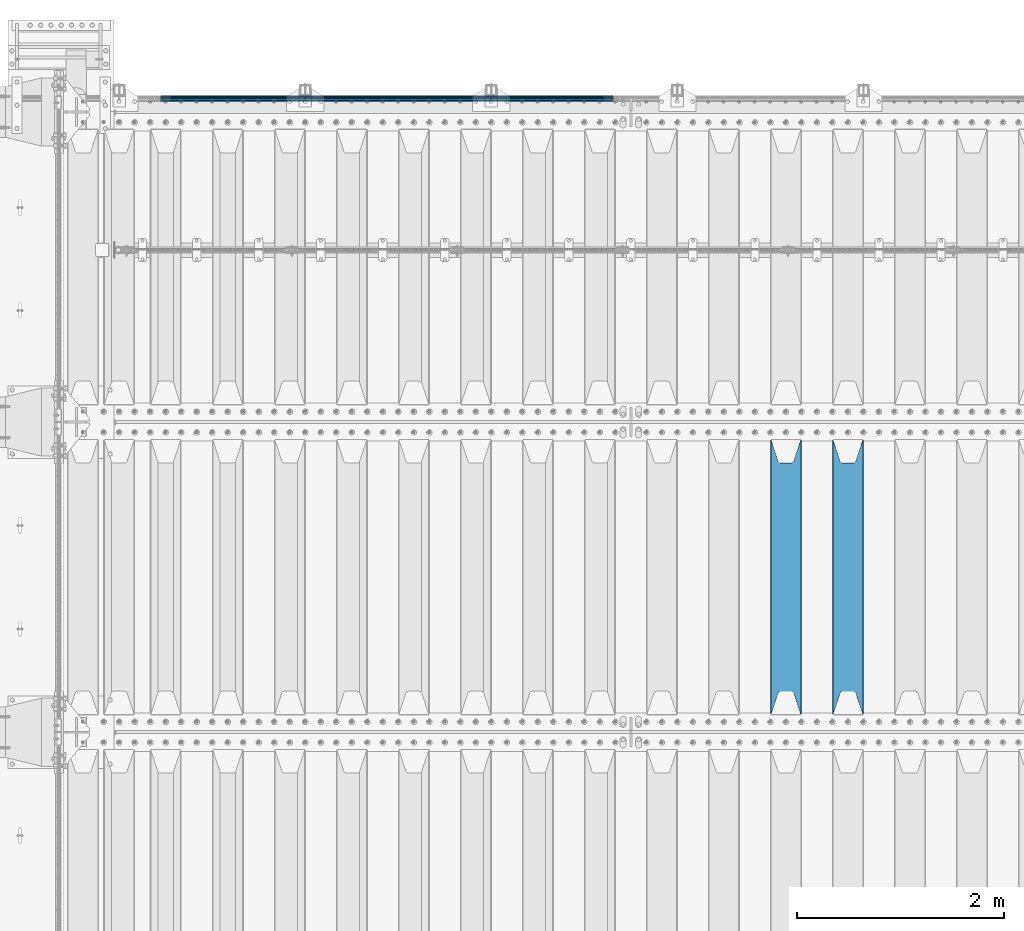
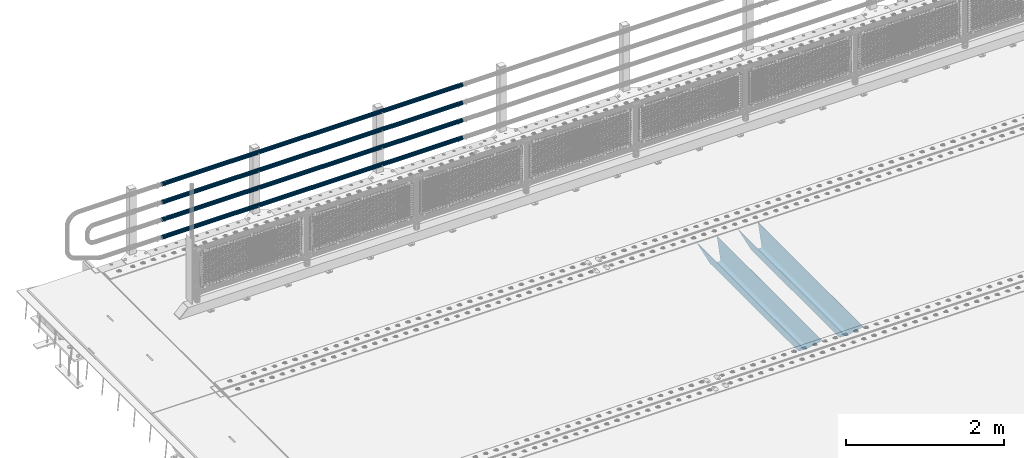
# One storey, part 120 of 257: 6 beams.
"""IFC2X3 building model written with IfcOpenShell, lengths in millimetres."""

import ifcopenshell
import ifcopenshell.guid

model = None  # the IFC model being written
_history = None  # IfcOwnerHistory: only IFC2X3 demands one
_inside = {}  # id of a spatial element -> (the spatial element, [elements in it])
_under = {}  # id of a project, library or spatial element -> (it, [spatial elements below it])
_declared = {}  # id of a project -> (the project, [libraries it declares])
_typed = {}  # id of a type object -> (the type object, [elements of that type])
_made_of = {}  # id of a material, layer set ... -> (it, [elements and type objects made of it])


def new_model(schema):
    """Start an empty IFC model of exactly this schema.

    Asked for "IFC4X3", IfcOpenShell would pick the latest addendum, in which some entities
    have other attributes; the version numbers below select the first issue.
    IFC2X3 requires an IfcOwnerHistory on every rooted entity: one is made here for all.
    """
    global model, _history
    if schema == "IFC4X3":
        model = ifcopenshell.file(schema_version=(4, 3, 0, 0))
    else:
        model = ifcopenshell.file(schema=schema)
    _inside.clear()
    _under.clear()
    _declared.clear()
    _typed.clear()
    _made_of.clear()
    _history = None
    if model.schema == "IFC2X3":
        org = make("IfcOrganization", Name="unknown")
        user = make(
            "IfcPersonAndOrganization",
            ThePerson=make("IfcPerson", FamilyName="unknown"),
            TheOrganization=org,
        )
        app = make(
            "IfcApplication",
            ApplicationDeveloper=org,
            Version="unknown",
            ApplicationFullName="unknown",
            ApplicationIdentifier="unknown",
        )
        _history = make(
            "IfcOwnerHistory",
            OwningUser=user,
            OwningApplication=app,
            ChangeAction="ADDED",
            CreationDate=0,
        )
    return model


def make(cls, **values):
    """One entity of the class cls with the attributes given. An attribute that is None is left unset."""
    return model.create_entity(
        cls, **{name: value for name, value in values.items() if value is not None}
    )


def rooted(cls, **values):
    """An entity with a GlobalId (a new one), such as an element, a storey or a relation."""
    return make(cls, GlobalId=ifcopenshell.guid.new(), OwnerHistory=_history, **values)


def si_unit(unit_type, name, prefix=None):
    """IfcSIUnit, for example si_unit("LENGTHUNIT", "METRE", prefix="MILLI")."""
    return make("IfcSIUnit", UnitType=unit_type, Prefix=prefix, Name=name)


def assignment(units):
    """IfcUnitAssignment: the units of a project."""
    return None if units is None else make("IfcUnitAssignment", Units=units)


def point(xyz):
    """IfcCartesianPoint."""
    return None if xyz is None else make("IfcCartesianPoint", Coordinates=xyz)


def direction(xyz):
    """IfcDirection."""
    return None if xyz is None else make("IfcDirection", DirectionRatios=xyz)


def frame(location, z_axis=None, x_axis=None):
    """IfcAxis2Placement3D, a coordinate frame: its origin and axes. An axis left out is left unset."""
    return make(
        "IfcAxis2Placement3D",
        Location=point(location),
        Axis=direction(z_axis),
        RefDirection=direction(x_axis),
    )


def origin_with_axes():
    """The frame at (0, 0, 0) with the z axis (0, 0, 1) and the x axis (1, 0, 0) written out."""
    return frame((0.0, 0.0, 0.0), z_axis=(0.0, 0.0, 1.0), x_axis=(1.0, 0.0, 0.0))


def place(relative_to, where):
    """IfcLocalPlacement: puts the frame where relative to a parent placement (None: the world)."""
    return make(
        "IfcLocalPlacement", PlacementRelTo=relative_to, RelativePlacement=where
    )


def context(
    kind, dimensions, precision=None, world=None, true_north=None, identifier=None
):
    """IfcGeometricRepresentationContext, for example the 3D "Model" context."""
    return make(
        "IfcGeometricRepresentationContext",
        ContextIdentifier=identifier,
        ContextType=kind,
        CoordinateSpaceDimension=dimensions,
        Precision=precision,
        WorldCoordinateSystem=world,
        TrueNorth=true_north,
    )


def subcontext(parent, identifier, kind, view, scale=None):
    """IfcGeometricRepresentationSubContext, for example "Body" below "Model"."""
    return make(
        "IfcGeometricRepresentationSubContext",
        ContextIdentifier=identifier,
        ContextType=kind,
        ParentContext=parent,
        TargetScale=scale,
        TargetView=view,
    )


def project(units=None, contexts=None):
    """IfcProject with its units and contexts."""
    return rooted(
        "IfcProject",
        Name="project",
        RepresentationContexts=contexts,
        UnitsInContext=assignment(units),
    )


def spatial(cls, under=None, at=None, **own):
    """A site, building, storey or space (cls), placed at a placement, below another one or the project."""
    s = rooted(cls, ObjectPlacement=at, **own)
    if under is not None:
        _under.setdefault(under.id(), (under, []))[1].append(s)
    return s


def faces_of(points, faces, orient=None, outer=None):
    """IfcFace entities. A face is a list of loops; a loop is a list of indices into points, from 0.

    orient and outer hold one flag for each loop. By default every Orientation is true, the
    first loop of a face is its IfcFaceOuterBound and the others are IfcFaceBound.
    """
    made = []
    for i, loops in enumerate(faces):
        bounds = []
        for j, loop in enumerate(loops):
            is_outer = j == 0 if outer is None else outer[i][j]
            bounds.append(
                make(
                    "IfcFaceOuterBound" if is_outer else "IfcFaceBound",
                    Bound=make("IfcPolyLoop", Polygon=[points[k] for k in loop]),
                    Orientation=True if orient is None else orient[i][j],
                )
            )
        made.append(make("IfcFace", Bounds=bounds))
    return made


def faceted_brep(points, faces, orient=None, outer=None, voids=None):
    """IfcFacetedBrep: a solid bounded by flat faces; with voids (closed shells), ...WithVoids."""
    shared = [point(p) for p in points]
    hull = make("IfcClosedShell", CfsFaces=faces_of(shared, faces, orient, outer))
    if voids is None:
        return make("IfcFacetedBrep", Outer=hull)
    return make(
        "IfcFacetedBrepWithVoids",
        Outer=hull,
        Voids=[
            make(cls, CfsFaces=faces_of(shared, fs, o, b)) for cls, fs, o, b in voids
        ],
    )


def shape(context_of_items, identifier, shape_type, items):
    """IfcShapeRepresentation: the items that make up one representation, for example the "Body"."""
    return make(
        "IfcShapeRepresentation",
        ContextOfItems=context_of_items,
        RepresentationIdentifier=identifier,
        RepresentationType=shape_type,
        Items=items,
    )


def material(Name=None, Category=None):
    """IfcMaterial."""
    return make("IfcMaterial", Name=Name, Category=Category)


def made_of(thing, what):
    """Note that an element or type object is made of a material, layer set ...; save() writes the relation."""
    if what is not None:
        _made_of.setdefault(what.id(), (what, []))[1].append(thing)
    return thing


def type_object(cls, material=None, **own):
    """A type object (cls), such as IfcWallType, which elements share."""
    return made_of(rooted(cls, **own), material)


def element(
    cls,
    number,
    at=None,
    inside=None,
    cuts=None,
    type_object=None,
    material=None,
    context=None,
    identifier="Body",
    shape_type=None,
    held_by="IfcProductDefinitionShape",
    body=None,
    shapes=None,
    **own,
):
    """One element of the class cls, such as IfcWall. Its Tag is "e" and its number.

    at: its placement. inside: the storey or other place that contains it. cuts: it is an
    opening in that element (IfcRelVoidsElement). A single representation is given by context,
    identifier, shape_type and body (its items); several are given by shapes. held_by: the class
    of the entity that holds the representations. save() writes the other relations.
    """
    e = rooted(cls, Tag="e%d" % number, ObjectPlacement=at, **own)
    if body is not None:
        shapes = [shape(context, identifier, shape_type, body)]
    if shapes is not None:
        e.Representation = make(held_by, Representations=shapes)
    if inside is not None:
        _inside.setdefault(inside.id(), (inside, []))[1].append(e)
    if cuts is not None:
        rooted(
            "IfcRelVoidsElement", RelatingBuildingElement=cuts, RelatedOpeningElement=e
        )
    if type_object is not None:
        _typed.setdefault(type_object.id(), (type_object, []))[1].append(e)
    return made_of(e, material)


def aggregate(whole, parts):
    """IfcRelAggregates: a whole, such as a stair, and the parts it consists of."""
    return rooted("IfcRelAggregates", RelatingObject=whole, RelatedObjects=parts)


def save(model, path):
    """Write the relations noted so far, then the file.

    IfcRelAggregates (storeys below a building ...), IfcRelContainedInSpatialStructure (elements
    in a storey), IfcRelDefinesByType, IfcRelAssociatesMaterial and IfcRelDeclares: one each for
    every whole, place, type object, material and project.
    """
    for whole, parts in _under.values():
        aggregate(whole, parts)
    for where, things in _inside.values():
        rooted(
            "IfcRelContainedInSpatialStructure",
            RelatedElements=things,
            RelatingStructure=where,
        )
    for kind, things in _typed.values():
        rooted("IfcRelDefinesByType", RelatedObjects=things, RelatingType=kind)
    for what, things in _made_of.values():
        rooted("IfcRelAssociatesMaterial", RelatedObjects=things, RelatingMaterial=what)
    for by, libraries in _declared.values():
        rooted("IfcRelDeclares", RelatingContext=by, RelatedDefinitions=libraries)
    model.write(path)


model = new_model("IFC2X3")

# Units and contexts
model_context = context("Model", 3, precision=1e-05, world=origin_with_axes())
body_context = subcontext(model_context, "Body", "Model", "MODEL_VIEW")
ifc_project = project(units=[si_unit("LENGTHUNIT", "METRE", prefix="MILLI"), si_unit("AREAUNIT", "SQUARE_METRE"), si_unit("VOLUMEUNIT", "CUBIC_METRE"), si_unit("MASSUNIT", "GRAM", prefix="KILO"), si_unit("TIMEUNIT", "SECOND"), si_unit("PLANEANGLEUNIT", "RADIAN"), si_unit("SOLIDANGLEUNIT", "STERADIAN"), si_unit("THERMODYNAMICTEMPERATUREUNIT", "DEGREE_CELSIUS"), si_unit("LUMINOUSINTENSITYUNIT", "LUMEN")], contexts=[model_context])

# Site, building, storey
site_placement = place(None, origin_with_axes())
site = spatial("IfcSite", under=ifc_project, at=site_placement, CompositionType="ELEMENT")
building_placement = place(site_placement, origin_with_axes())
building = spatial("IfcBuilding", under=site, at=building_placement, Name="Standard", CompositionType="ELEMENT")
storey_placement = place(building_placement, origin_with_axes())
storey = spatial("IfcBuildingStorey", under=building, at=storey_placement, Name="Undefined", CompositionType="ELEMENT", Elevation=0.0)

# Beams
ifc_material_1 = material(Name="STEEL/S355N")
beam_type_1 = type_object("IfcBeamType", PredefinedType="NOTDEFINED")
beam_1_placement = place(storey_placement, frame((50050.0, 6175.0, -115.0), z_axis=(0.0, 0.0, 1.0), x_axis=(0.0, 1.0, 0.0)))
element("IfcBeam", 1, at=beam_1_placement, inside=storey, type_object=beam_type_1, material=ifc_material_1, context=body_context, shape_type="Brep", body=[
    faceted_brep([(0.0, 150.0, 115.0), (0.0, 143.690000000002, 115.0), (2650.00000000297, 143.690000000002, 115.0), (2650.00000000297, 150.0, 115.0), (2650.00000000297, 142.059565218406, 110.0000000031), (2650.00000000297, 148.369565218403, 110.0000000031), (2441.90079219208, -80.1103600731149, -98.0992078077845), (2437.7588105432, -77.5672621345584, -102.241189456673), (2434.06523489746, -74.4080125315522, -105.934765102404), (2430.91086095089, -70.7102721255724, -109.089139048974), (2428.37322971128, -66.5649389910031, -111.626770288588), (2426.51472138055, -62.0739139532889, -113.485278619323), (2425.38102192091, -57.3475956567636, -114.618978078955), (2424.99999999987, -52.5021667386536, -115.0), (2424.99999999987, 52.5021667386536, -115.0), (2425.38102192091, 57.3475956567636, -114.618978078955), (2426.51472138055, 62.0739139532889, -113.485278619323), (2428.37322971128, 66.5649389910031, -111.626770288588), (2430.91086095089, 70.7102721255724, -109.089139048974), (2434.06523489746, 74.4080125315522, -105.934765102404), (2437.7588105432, 77.5672621345584, -102.241189456673), (2441.90079219208, 80.1103600731149, -98.0992078077846), (2446.38936140511, 81.9747917625791, -93.6106385947584), (2448.24948500409, 76.2713538057287, -91.7505149957729), (2444.62967112262, 74.76777986261, -95.3703288772456), (2441.28936334126, 72.7168944282894, -98.710636658607), (2438.31067330438, 70.1691124903809, -101.689326695487), (2435.76682334747, 67.1870637758839, -104.233176652398), (2433.72034654133, 63.8440531834931, -106.279653458539), (2432.22154950041, 60.2222587982324, -107.778450499454), (2431.30727574265, 56.4107117849126, -108.692724257221), (2430.99999999987, 52.5031078186876, -109.0), (2430.99999999987, -52.5031078186876, -109.0), (2431.30727574265, -56.4107117849126, -108.692724257221), (2432.22154950041, -60.2222587982324, -107.778450499454), (2433.72034654133, -63.8440531834931, -106.279653458539), (2435.76682334747, -67.1870637758839, -104.233176652398), (2438.31067330438, -70.1691124903809, -101.689326695487), (2441.28936334126, -72.7168944282894, -98.7106366586071), (2444.62967112262, -74.76777986261, -95.3703288772457), (2448.24948500409, -76.2713538057287, -91.7505149957729), (2650.00000000297, -142.059565218406, 110.0000000031), (2650.00000000297, -148.369565218403, 110.0000000031), (2446.38936140511, -81.9747917625791, -93.6106385947584), (2650.00000000297, -143.690000000002, 115.0), (2650.00000000297, -150.0, 115.0), (0.0, -143.690000000002, 115.0), (0.0, -150.0, 115.0), (0.0, -148.369565218258, 110.000000002662), (203.61063859742, -81.9747917625791, -93.6106385947584), (208.099207810447, -80.1103600731149, -98.0992078077845), (212.241189459335, -77.5672621345584, -102.241189456673), (215.934765105066, -74.4080125315522, -105.934765102404), (219.089139051636, -70.7102721255724, -109.089139048974), (221.626770291251, -66.5649389910031, -111.626770288588), (223.485278621985, -62.0739139532889, -113.485278619323), (224.618978081617, -57.3475956567636, -114.618978078955), (225.000000002662, -52.5021667386536, -115.0), (225.000000002662, 52.5021667386536, -115.0), (224.618978081617, 57.3475956567636, -114.618978078955), (223.485278621985, 62.0739139532889, -113.485278619323), (221.626770291251, 66.5649389910031, -111.626770288588), (219.089139051636, 70.7102721255724, -109.089139048974), (215.934765105066, 74.4080125315522, -105.934765102404), (212.241189459335, 77.5672621345584, -102.241189456673), (208.099207810447, 80.1103600731149, -98.0992078077846), (203.61063859742, 81.9747917625791, -93.6106385947584), (0.0, 148.369565218258, 110.000000002662), (0.0, 142.05956521826, 110.000000002662), (201.750514998435, 76.2713538057287, -91.7505149957729), (205.370328879908, 74.76777986261, -95.3703288772456), (208.710636661269, 72.7168944282894, -98.710636658607), (211.689326698149, 70.1691124903809, -101.689326695487), (214.233176655061, 67.1870637758839, -104.233176652398), (216.279653461201, 63.8440531834931, -106.279653458539), (217.778450502116, 60.2222587982324, -107.778450499454), (218.692724259884, 56.4107117849126, -108.692724257221), (219.000000002662, 52.5031078186876, -109.0), (219.000000002662, -52.5031078186876, -109.0), (218.692724259884, -56.4107117849126, -108.692724257221), (217.778450502116, -60.2222587982324, -107.778450499454), (216.279653461201, -63.8440531834931, -106.279653458539), (214.233176655061, -67.1870637758839, -104.233176652398), (211.689326698149, -70.1691124903809, -101.689326695487), (208.710636661269, -72.7168944282894, -98.7106366586071), (205.370328879908, -74.76777986261, -95.3703288772457), (201.750514998435, -76.2713538057287, -91.7505149957729), (0.0, -142.05956521826, 110.000000002662)], [[[0, 1, 2, 3]], [[3, 2, 4, 5]], [[6, 7, 8, 9, 10, 11, 12, 13, 14, 15, 16, 17, 18, 19, 20, 21, 22, 5, 4, 23, 24, 25, 26, 27, 28, 29, 30, 31, 32, 33, 34, 35, 36, 37, 38, 39, 40, 41, 42, 43]], [[44, 45, 42, 41]], [[46, 47, 45, 44]], [[43, 42, 45, 47, 48, 49]], [[6, 43, 49, 50]], [[7, 6, 50, 51]], [[8, 7, 51, 52]], [[9, 8, 52, 53]], [[10, 9, 53, 54]], [[11, 10, 54, 55]], [[12, 11, 55, 56]], [[13, 12, 56, 57]], [[14, 13, 57, 58]], [[15, 14, 58, 59]], [[16, 15, 59, 60]], [[17, 16, 60, 61]], [[18, 17, 61, 62]], [[19, 18, 62, 63]], [[20, 19, 63, 64]], [[21, 20, 64, 65]], [[22, 21, 65, 66]], [[0, 3, 5, 22, 66, 67]], [[1, 0, 67, 68]], [[23, 4, 2, 1, 68, 69]], [[24, 23, 69, 70]], [[25, 24, 70, 71]], [[26, 25, 71, 72]], [[27, 26, 72, 73]], [[28, 27, 73, 74]], [[29, 28, 74, 75]], [[30, 29, 75, 76]], [[31, 30, 76, 77]], [[32, 31, 77, 78]], [[33, 32, 78, 79]], [[34, 33, 79, 80]], [[35, 34, 80, 81]], [[36, 35, 81, 82]], [[37, 36, 82, 83]], [[38, 37, 83, 84]], [[39, 38, 84, 85]], [[40, 39, 85, 86]], [[46, 44, 41, 40, 86, 87]], [[47, 46, 87, 48]], [[86, 85, 84, 83, 82, 81, 80, 79, 78, 77, 76, 75, 74, 73, 72, 71, 70, 69, 68, 67, 66, 65, 64, 63, 62, 61, 60, 59, 58, 57, 56, 55, 54, 53, 52, 51, 50, 49, 48, 87]]]),
])
beam_2_placement = place(storey_placement, frame((49450.0, 6175.0, -115.0), z_axis=(0.0, 0.0, 1.0), x_axis=(0.0, 1.0, 0.0)))
element("IfcBeam", 2, at=beam_2_placement, inside=storey, type_object=beam_type_1, material=ifc_material_1, context=body_context, shape_type="Brep", body=[
    faceted_brep([(0.0, 150.0, 115.0), (0.0, 143.690000000002, 115.0), (2650.00000000297, 143.690000000002, 115.0), (2650.00000000297, 150.0, 115.0), (2650.00000000297, 142.059565218406, 110.0000000031), (2650.00000000297, 148.369565218403, 110.0000000031), (2441.90079219208, -80.1103600731149, -98.0992078077845), (2437.7588105432, -77.5672621345584, -102.241189456673), (2434.06523489746, -74.4080125315522, -105.934765102404), (2430.91086095089, -70.7102721255724, -109.089139048974), (2428.37322971128, -66.5649389910031, -111.626770288588), (2426.51472138055, -62.0739139532889, -113.485278619323), (2425.38102192091, -57.3475956567636, -114.618978078955), (2424.99999999987, -52.5021667386536, -115.0), (2424.99999999987, 52.5021667386536, -115.0), (2425.38102192091, 57.3475956567636, -114.618978078955), (2426.51472138055, 62.0739139532889, -113.485278619323), (2428.37322971128, 66.5649389910031, -111.626770288588), (2430.91086095089, 70.7102721255724, -109.089139048974), (2434.06523489746, 74.4080125315522, -105.934765102404), (2437.7588105432, 77.5672621345584, -102.241189456673), (2441.90079219208, 80.1103600731149, -98.0992078077846), (2446.38936140511, 81.9747917625791, -93.6106385947584), (2448.24948500409, 76.2713538057287, -91.7505149957729), (2444.62967112262, 74.76777986261, -95.3703288772456), (2441.28936334126, 72.7168944282894, -98.710636658607), (2438.31067330438, 70.1691124903809, -101.689326695487), (2435.76682334747, 67.1870637758839, -104.233176652398), (2433.72034654133, 63.8440531834931, -106.279653458539), (2432.22154950041, 60.2222587982324, -107.778450499454), (2431.30727574265, 56.4107117849126, -108.692724257221), (2430.99999999987, 52.5031078186876, -109.0), (2430.99999999987, -52.5031078186876, -109.0), (2431.30727574265, -56.4107117849126, -108.692724257221), (2432.22154950041, -60.2222587982324, -107.778450499454), (2433.72034654133, -63.8440531834931, -106.279653458539), (2435.76682334747, -67.1870637758839, -104.233176652398), (2438.31067330438, -70.1691124903809, -101.689326695487), (2441.28936334126, -72.7168944282894, -98.7106366586071), (2444.62967112262, -74.76777986261, -95.3703288772457), (2448.24948500409, -76.2713538057287, -91.7505149957729), (2650.00000000297, -142.059565218406, 110.0000000031), (2650.00000000297, -148.369565218403, 110.0000000031), (2446.38936140511, -81.9747917625791, -93.6106385947584), (2650.00000000297, -143.690000000002, 115.0), (2650.00000000297, -150.0, 115.0), (0.0, -143.690000000002, 115.0), (0.0, -150.0, 115.0), (0.0, -148.369565218258, 110.000000002662), (203.61063859742, -81.9747917625791, -93.6106385947584), (208.099207810447, -80.1103600731149, -98.0992078077845), (212.241189459335, -77.5672621345584, -102.241189456673), (215.934765105066, -74.4080125315522, -105.934765102404), (219.089139051636, -70.7102721255724, -109.089139048974), (221.626770291251, -66.5649389910031, -111.626770288588), (223.485278621985, -62.0739139532889, -113.485278619323), (224.618978081617, -57.3475956567636, -114.618978078955), (225.000000002662, -52.5021667386536, -115.0), (225.000000002662, 52.5021667386536, -115.0), (224.618978081617, 57.3475956567636, -114.618978078955), (223.485278621985, 62.0739139532889, -113.485278619323), (221.626770291251, 66.5649389910031, -111.626770288588), (219.089139051636, 70.7102721255724, -109.089139048974), (215.934765105066, 74.4080125315522, -105.934765102404), (212.241189459335, 77.5672621345584, -102.241189456673), (208.099207810447, 80.1103600731149, -98.0992078077846), (203.61063859742, 81.9747917625791, -93.6106385947584), (0.0, 148.369565218258, 110.000000002662), (0.0, 142.05956521826, 110.000000002662), (201.750514998435, 76.2713538057287, -91.7505149957729), (205.370328879908, 74.76777986261, -95.3703288772456), (208.710636661269, 72.7168944282894, -98.710636658607), (211.689326698149, 70.1691124903809, -101.689326695487), (214.233176655061, 67.1870637758839, -104.233176652398), (216.279653461201, 63.8440531834931, -106.279653458539), (217.778450502116, 60.2222587982324, -107.778450499454), (218.692724259884, 56.4107117849126, -108.692724257221), (219.000000002662, 52.5031078186876, -109.0), (219.000000002662, -52.5031078186876, -109.0), (218.692724259884, -56.4107117849126, -108.692724257221), (217.778450502116, -60.2222587982324, -107.778450499454), (216.279653461201, -63.8440531834931, -106.279653458539), (214.233176655061, -67.1870637758839, -104.233176652398), (211.689326698149, -70.1691124903809, -101.689326695487), (208.710636661269, -72.7168944282894, -98.7106366586071), (205.370328879908, -74.76777986261, -95.3703288772457), (201.750514998435, -76.2713538057287, -91.7505149957729), (0.0, -142.05956521826, 110.000000002662)], [[[0, 1, 2, 3]], [[3, 2, 4, 5]], [[6, 7, 8, 9, 10, 11, 12, 13, 14, 15, 16, 17, 18, 19, 20, 21, 22, 5, 4, 23, 24, 25, 26, 27, 28, 29, 30, 31, 32, 33, 34, 35, 36, 37, 38, 39, 40, 41, 42, 43]], [[44, 45, 42, 41]], [[46, 47, 45, 44]], [[43, 42, 45, 47, 48, 49]], [[6, 43, 49, 50]], [[7, 6, 50, 51]], [[8, 7, 51, 52]], [[9, 8, 52, 53]], [[10, 9, 53, 54]], [[11, 10, 54, 55]], [[12, 11, 55, 56]], [[13, 12, 56, 57]], [[14, 13, 57, 58]], [[15, 14, 58, 59]], [[16, 15, 59, 60]], [[17, 16, 60, 61]], [[18, 17, 61, 62]], [[19, 18, 62, 63]], [[20, 19, 63, 64]], [[21, 20, 64, 65]], [[22, 21, 65, 66]], [[0, 3, 5, 22, 66, 67]], [[1, 0, 67, 68]], [[23, 4, 2, 1, 68, 69]], [[24, 23, 69, 70]], [[25, 24, 70, 71]], [[26, 25, 71, 72]], [[27, 26, 72, 73]], [[28, 27, 73, 74]], [[29, 28, 74, 75]], [[30, 29, 75, 76]], [[31, 30, 76, 77]], [[32, 31, 77, 78]], [[33, 32, 78, 79]], [[34, 33, 79, 80]], [[35, 34, 80, 81]], [[36, 35, 81, 82]], [[37, 36, 82, 83]], [[38, 37, 83, 84]], [[39, 38, 84, 85]], [[40, 39, 85, 86]], [[46, 44, 41, 40, 86, 87]], [[47, 46, 87, 48]], [[86, 85, 84, 83, 82, 81, 80, 79, 78, 77, 76, 75, 74, 73, 72, 71, 70, 69, 68, 67, 66, 65, 64, 63, 62, 61, 60, 59, 58, 57, 56, 55, 54, 53, 52, 51, 50, 49, 48, 87]]]),
])
ifc_material_2 = material()
beam_type_2 = type_object("IfcBeamType", PredefinedType="NOTDEFINED")
beam_3_placement = place(storey_placement, frame((47783.9999999999, 12129.8500000001, 149.849999999725), z_axis=(0.0, 0.0, -1.0), x_axis=(-1.0, 0.0, 0.0)))
element("IfcBeam", 3, at=beam_3_placement, inside=storey, type_object=beam_type_2, material=ifc_material_2, context=body_context, shape_type="Brep", body=[
    faceted_brep([(0.0, -26.5499999999993, 0.0), (0.0, -24.5290015881747, 10.1602451292931), (4384.00249699992, -24.5290015881747, 10.1602451292931), (4384.00249699992, -26.5499999999993, 0.0), (0.0, -18.7736850405036, 18.7736850405028), (4384.00249699992, -18.7736850405036, 18.7736850405028), (0.0, -10.1602451292929, 24.5290015881747), (4384.00249699992, -10.1602451292929, 24.5290015881747), (0.0, 0.0, 26.55), (4384.00249699992, 0.0, 26.55), (0.0, 10.1602451292929, 24.5290015881747), (4384.00249699992, 10.1602451292929, 24.5290015881747), (0.0, 18.7736850405036, 18.7736850405028), (4384.00249699992, 18.7736850405036, 18.7736850405028), (0.0, 24.5290015881747, 10.1602451292931), (4384.00249699992, 24.5290015881747, 10.1602451292931), (0.0, 26.5499999999993, 0.0), (4384.00249699992, 26.5499999999993, 0.0), (0.0, 24.5290015881747, -10.1602451292931), (4384.00249699992, 24.5290015881747, -10.1602451292931), (0.0, 18.7736850405036, -18.7736850405028), (4384.00249699992, 18.7736850405036, -18.7736850405028), (0.0, 10.1602451292929, -24.5290015881747), (4384.00249699992, 10.1602451292929, -24.5290015881747), (0.0, 0.0, -26.55), (4384.00249699992, 0.0, -26.55), (0.0, -10.1602451292929, -24.5290015881747), (4384.00249699992, -10.1602451292929, -24.5290015881747), (0.0, -18.7736850405036, -18.7736850405028), (4384.00249699992, -18.7736850405036, -18.7736850405028), (0.0, -24.5290015881747, -10.1602451292931), (4384.00249699992, -24.5290015881747, -10.1602451292931), (0.0, -30.1499999999996, 0.0), (0.0, -27.8549679052157, -11.5379054858058), (4384.00249699992, -27.8549679052157, -11.5379054858075), (4384.00249699992, -30.1499999999996, 0.0), (0.0, -21.3192694527752, -21.3192694527752), (4384.00249699992, -21.3192694527752, -21.3192694527744), (0.0, -11.5379054858076, -27.8549679052157), (4384.00249699992, -11.5379054858076, -27.8549679052153), (0.0, 0.0, -30.1500000000015), (4384.00249699992, 0.0, -30.15), (0.0, 11.5379054858076, -27.8549679052157), (4384.00249699992, 11.5379054858076, -27.8549679052153), (0.0, 21.3192694527752, -21.3192694527752), (4384.00249699992, 21.3192694527752, -21.3192694527744), (0.0, 27.8549679052157, -11.5379054858058), (4384.00249699992, 27.8549679052157, -11.5379054858074), (0.0, 30.1499999999996, 0.0), (4384.00249699992, 30.1499999999996, 0.0), (0.0, 27.8549679052157, 11.5379054858058), (4384.00249699992, 27.8549679052157, 11.5379054858075), (0.0, 21.3192694527752, 21.3192694527752), (4384.00249699992, 21.3192694527752, 21.3192694527744), (0.0, 11.5379054858076, 27.8549679052157), (4384.00249699992, 11.5379054858076, 27.8549679052153), (0.0, 0.0, 30.1500000000015), (4384.00249699992, 0.0, 30.15), (0.0, -11.5379054858076, 27.8549679052157), (4384.00249699992, -11.5379054858076, 27.8549679052153), (0.0, -21.3192694527752, 21.3192694527752), (4384.00249699992, -21.3192694527752, 21.3192694527744), (0.0, -27.8549679052157, 11.5379054858058), (4384.00249699992, -27.8549679052157, 11.5379054858075)], [[[0, 1, 2, 3]], [[1, 4, 5, 2]], [[4, 6, 7, 5]], [[6, 8, 9, 7]], [[8, 10, 11, 9]], [[10, 12, 13, 11]], [[12, 14, 15, 13]], [[14, 16, 17, 15]], [[16, 18, 19, 17]], [[18, 20, 21, 19]], [[20, 22, 23, 21]], [[22, 24, 25, 23]], [[24, 26, 27, 25]], [[26, 28, 29, 27]], [[28, 30, 31, 29]], [[30, 0, 3, 31]], [[32, 33, 34, 35]], [[33, 36, 37, 34]], [[36, 38, 39, 37]], [[38, 40, 41, 39]], [[40, 42, 43, 41]], [[42, 44, 45, 43]], [[44, 46, 47, 45]], [[46, 48, 49, 47]], [[48, 50, 51, 49]], [[50, 52, 53, 51]], [[52, 54, 55, 53]], [[54, 56, 57, 55]], [[56, 58, 59, 57]], [[58, 60, 61, 59]], [[60, 62, 63, 61]], [[62, 32, 35, 63]], [[37, 39, 41, 43, 45, 47, 49, 51, 53, 55, 57, 59, 61, 63, 35, 34], [5, 7, 9, 11, 13, 15, 17, 19, 21, 23, 25, 27, 29, 31, 3, 2]], [[62, 60, 58, 56, 54, 52, 50, 48, 46, 44, 42, 40, 38, 36, 33, 32], [30, 28, 26, 24, 22, 20, 18, 16, 14, 12, 10, 8, 6, 4, 1, 0]]]),
])
beam_4_placement = place(storey_placement, frame((47783.9999999999, 12129.8500000001, 420.149999999728), z_axis=(0.0, 0.0, -1.0), x_axis=(-1.0, 0.0, 0.0)))
element("IfcBeam", 4, at=beam_4_placement, inside=storey, type_object=beam_type_2, material=ifc_material_2, context=body_context, shape_type="Brep", body=[
    faceted_brep([(0.0, -26.5499999999993, 0.0), (0.0, -24.5290015881747, 10.1602451292931), (4384.00249699992, -24.5290015881747, 10.1602451292931), (4384.00249699992, -26.5499999999993, 0.0), (0.0, -18.7736850405036, 18.7736850405028), (4384.00249699992, -18.7736850405036, 18.7736850405028), (0.0, -10.1602451292929, 24.5290015881747), (4384.00249699992, -10.1602451292929, 24.5290015881747), (0.0, 0.0, 26.55), (4384.00249699992, 0.0, 26.55), (0.0, 10.1602451292929, 24.5290015881747), (4384.00249699992, 10.1602451292929, 24.5290015881747), (0.0, 18.7736850405036, 18.7736850405028), (4384.00249699992, 18.7736850405036, 18.7736850405028), (0.0, 24.5290015881747, 10.1602451292931), (4384.00249699992, 24.5290015881747, 10.1602451292931), (0.0, 26.5499999999993, 0.0), (4384.00249699992, 26.5499999999993, 0.0), (0.0, 24.5290015881747, -10.1602451292931), (4384.00249699992, 24.5290015881747, -10.1602451292931), (0.0, 18.7736850405036, -18.7736850405028), (4384.00249699992, 18.7736850405036, -18.7736850405028), (0.0, 10.1602451292929, -24.5290015881747), (4384.00249699992, 10.1602451292929, -24.5290015881747), (0.0, 0.0, -26.55), (4384.00249699992, 0.0, -26.55), (0.0, -10.1602451292929, -24.5290015881747), (4384.00249699992, -10.1602451292929, -24.5290015881747), (0.0, -18.7736850405036, -18.7736850405028), (4384.00249699992, -18.7736850405036, -18.7736850405028), (0.0, -24.5290015881747, -10.1602451292931), (4384.00249699992, -24.5290015881747, -10.1602451292931), (0.0, -30.1499999999996, 0.0), (0.0, -27.8549679052157, -11.5379054858058), (4384.00249699992, -27.8549679052157, -11.5379054858075), (4384.00249699992, -30.1499999999996, 0.0), (0.0, -21.3192694527752, -21.3192694527752), (4384.00249699992, -21.3192694527752, -21.3192694527744), (0.0, -11.5379054858076, -27.8549679052157), (4384.00249699992, -11.5379054858076, -27.8549679052153), (0.0, 0.0, -30.1500000000015), (4384.00249699992, 0.0, -30.15), (0.0, 11.5379054858076, -27.8549679052157), (4384.00249699992, 11.5379054858076, -27.8549679052153), (0.0, 21.3192694527752, -21.3192694527752), (4384.00249699992, 21.3192694527752, -21.3192694527744), (0.0, 27.8549679052157, -11.5379054858058), (4384.00249699992, 27.8549679052157, -11.5379054858074), (0.0, 30.1499999999996, 0.0), (4384.00249699992, 30.1499999999996, 0.0), (0.0, 27.8549679052157, 11.5379054858058), (4384.00249699992, 27.8549679052157, 11.5379054858075), (0.0, 21.3192694527752, 21.3192694527752), (4384.00249699992, 21.3192694527752, 21.3192694527744), (0.0, 11.5379054858076, 27.8549679052157), (4384.00249699992, 11.5379054858076, 27.8549679052153), (0.0, 0.0, 30.1500000000015), (4384.00249699992, 0.0, 30.15), (0.0, -11.5379054858076, 27.8549679052157), (4384.00249699992, -11.5379054858076, 27.8549679052153), (0.0, -21.3192694527752, 21.3192694527752), (4384.00249699992, -21.3192694527752, 21.3192694527744), (0.0, -27.8549679052157, 11.5379054858058), (4384.00249699992, -27.8549679052157, 11.5379054858075)], [[[0, 1, 2, 3]], [[1, 4, 5, 2]], [[4, 6, 7, 5]], [[6, 8, 9, 7]], [[8, 10, 11, 9]], [[10, 12, 13, 11]], [[12, 14, 15, 13]], [[14, 16, 17, 15]], [[16, 18, 19, 17]], [[18, 20, 21, 19]], [[20, 22, 23, 21]], [[22, 24, 25, 23]], [[24, 26, 27, 25]], [[26, 28, 29, 27]], [[28, 30, 31, 29]], [[30, 0, 3, 31]], [[32, 33, 34, 35]], [[33, 36, 37, 34]], [[36, 38, 39, 37]], [[38, 40, 41, 39]], [[40, 42, 43, 41]], [[42, 44, 45, 43]], [[44, 46, 47, 45]], [[46, 48, 49, 47]], [[48, 50, 51, 49]], [[50, 52, 53, 51]], [[52, 54, 55, 53]], [[54, 56, 57, 55]], [[56, 58, 59, 57]], [[58, 60, 61, 59]], [[60, 62, 63, 61]], [[62, 32, 35, 63]], [[37, 39, 41, 43, 45, 47, 49, 51, 53, 55, 57, 59, 61, 63, 35, 34], [5, 7, 9, 11, 13, 15, 17, 19, 21, 23, 25, 27, 29, 31, 3, 2]], [[62, 60, 58, 56, 54, 52, 50, 48, 46, 44, 42, 40, 38, 36, 33, 32], [30, 28, 26, 24, 22, 20, 18, 16, 14, 12, 10, 8, 6, 4, 1, 0]]]),
])
beam_5_placement = place(storey_placement, frame((47783.9999999999, 12129.8500000001, 969.849999999725), z_axis=(0.0, 0.0, -1.0), x_axis=(-1.0, 0.0, 0.0)))
element("IfcBeam", 5, at=beam_5_placement, inside=storey, type_object=beam_type_2, material=ifc_material_2, context=body_context, shape_type="Brep", body=[
    faceted_brep([(0.0, -26.5499999999993, 0.0), (0.0, -24.5290015881747, 10.1602451292931), (4384.00249699992, -24.5290015881747, 10.1602451292931), (4384.00249699992, -26.5499999999993, 0.0), (0.0, -18.7736850405036, 18.7736850405028), (4384.00249699992, -18.7736850405036, 18.7736850405028), (0.0, -10.1602451292929, 24.5290015881747), (4384.00249699992, -10.1602451292929, 24.5290015881747), (0.0, 0.0, 26.55), (4384.00249699992, 0.0, 26.55), (0.0, 10.1602451292929, 24.5290015881747), (4384.00249699992, 10.1602451292929, 24.5290015881747), (0.0, 18.7736850405036, 18.7736850405028), (4384.00249699992, 18.7736850405036, 18.7736850405028), (0.0, 24.5290015881747, 10.1602451292931), (4384.00249699992, 24.5290015881747, 10.1602451292931), (0.0, 26.5499999999993, 0.0), (4384.00249699992, 26.5499999999993, 0.0), (0.0, 24.5290015881747, -10.1602451292931), (4384.00249699992, 24.5290015881747, -10.1602451292931), (0.0, 18.7736850405036, -18.7736850405028), (4384.00249699992, 18.7736850405036, -18.7736850405028), (0.0, 10.1602451292929, -24.5290015881747), (4384.00249699992, 10.1602451292929, -24.5290015881747), (0.0, 0.0, -26.55), (4384.00249699992, 0.0, -26.55), (0.0, -10.1602451292929, -24.5290015881747), (4384.00249699992, -10.1602451292929, -24.5290015881747), (0.0, -18.7736850405036, -18.7736850405028), (4384.00249699992, -18.7736850405036, -18.7736850405028), (0.0, -24.5290015881747, -10.1602451292931), (4384.00249699992, -24.5290015881747, -10.1602451292931), (0.0, -30.1499999999996, 0.0), (0.0, -27.8549679052157, -11.5379054858058), (4384.00249699992, -27.8549679052157, -11.5379054858075), (4384.00249699992, -30.1499999999996, 0.0), (0.0, -21.3192694527752, -21.3192694527752), (4384.00249699992, -21.3192694527752, -21.3192694527744), (0.0, -11.5379054858076, -27.8549679052157), (4384.00249699992, -11.5379054858076, -27.8549679052153), (0.0, 0.0, -30.1500000000015), (4384.00249699992, 0.0, -30.15), (0.0, 11.5379054858076, -27.8549679052157), (4384.00249699992, 11.5379054858076, -27.8549679052153), (0.0, 21.3192694527752, -21.3192694527752), (4384.00249699992, 21.3192694527752, -21.3192694527744), (0.0, 27.8549679052157, -11.5379054858058), (4384.00249699992, 27.8549679052157, -11.5379054858074), (0.0, 30.1499999999996, 0.0), (4384.00249699992, 30.1499999999996, 0.0), (0.0, 27.8549679052157, 11.5379054858058), (4384.00249699992, 27.8549679052157, 11.5379054858075), (0.0, 21.3192694527752, 21.3192694527752), (4384.00249699992, 21.3192694527752, 21.3192694527744), (0.0, 11.5379054858076, 27.8549679052157), (4384.00249699992, 11.5379054858076, 27.8549679052153), (0.0, 0.0, 30.1500000000015), (4384.00249699992, 0.0, 30.15), (0.0, -11.5379054858076, 27.8549679052157), (4384.00249699992, -11.5379054858076, 27.8549679052153), (0.0, -21.3192694527752, 21.3192694527752), (4384.00249699992, -21.3192694527752, 21.3192694527744), (0.0, -27.8549679052157, 11.5379054858058), (4384.00249699992, -27.8549679052157, 11.5379054858075)], [[[0, 1, 2, 3]], [[1, 4, 5, 2]], [[4, 6, 7, 5]], [[6, 8, 9, 7]], [[8, 10, 11, 9]], [[10, 12, 13, 11]], [[12, 14, 15, 13]], [[14, 16, 17, 15]], [[16, 18, 19, 17]], [[18, 20, 21, 19]], [[20, 22, 23, 21]], [[22, 24, 25, 23]], [[24, 26, 27, 25]], [[26, 28, 29, 27]], [[28, 30, 31, 29]], [[30, 0, 3, 31]], [[32, 33, 34, 35]], [[33, 36, 37, 34]], [[36, 38, 39, 37]], [[38, 40, 41, 39]], [[40, 42, 43, 41]], [[42, 44, 45, 43]], [[44, 46, 47, 45]], [[46, 48, 49, 47]], [[48, 50, 51, 49]], [[50, 52, 53, 51]], [[52, 54, 55, 53]], [[54, 56, 57, 55]], [[56, 58, 59, 57]], [[58, 60, 61, 59]], [[60, 62, 63, 61]], [[62, 32, 35, 63]], [[37, 39, 41, 43, 45, 47, 49, 51, 53, 55, 57, 59, 61, 63, 35, 34], [5, 7, 9, 11, 13, 15, 17, 19, 21, 23, 25, 27, 29, 31, 3, 2]], [[62, 60, 58, 56, 54, 52, 50, 48, 46, 44, 42, 40, 38, 36, 33, 32], [30, 28, 26, 24, 22, 20, 18, 16, 14, 12, 10, 8, 6, 4, 1, 0]]]),
])
beam_6_placement = place(storey_placement, frame((47783.9999999999, 12129.8500000001, 689.849999999725), z_axis=(0.0, 0.0, -1.0), x_axis=(-1.0, 0.0, 0.0)))
element("IfcBeam", 6, at=beam_6_placement, inside=storey, type_object=beam_type_2, material=ifc_material_2, context=body_context, shape_type="Brep", body=[
    faceted_brep([(0.0, -26.5499999999993, 0.0), (0.0, -24.5290015881747, 10.1602451292931), (4384.00249699992, -24.5290015881747, 10.1602451292931), (4384.00249699992, -26.5499999999993, 0.0), (0.0, -18.7736850405036, 18.7736850405028), (4384.00249699992, -18.7736850405036, 18.7736850405028), (0.0, -10.1602451292929, 24.5290015881747), (4384.00249699992, -10.1602451292929, 24.5290015881747), (0.0, 0.0, 26.55), (4384.00249699992, 0.0, 26.55), (0.0, 10.1602451292929, 24.5290015881747), (4384.00249699992, 10.1602451292929, 24.5290015881747), (0.0, 18.7736850405036, 18.7736850405028), (4384.00249699992, 18.7736850405036, 18.7736850405028), (0.0, 24.5290015881747, 10.1602451292931), (4384.00249699992, 24.5290015881747, 10.1602451292931), (0.0, 26.5499999999993, 0.0), (4384.00249699992, 26.5499999999993, 0.0), (0.0, 24.5290015881747, -10.1602451292931), (4384.00249699992, 24.5290015881747, -10.1602451292931), (0.0, 18.7736850405036, -18.7736850405028), (4384.00249699992, 18.7736850405036, -18.7736850405028), (0.0, 10.1602451292929, -24.5290015881747), (4384.00249699992, 10.1602451292929, -24.5290015881747), (0.0, 0.0, -26.55), (4384.00249699992, 0.0, -26.55), (0.0, -10.1602451292929, -24.5290015881747), (4384.00249699992, -10.1602451292929, -24.5290015881747), (0.0, -18.7736850405036, -18.7736850405028), (4384.00249699992, -18.7736850405036, -18.7736850405028), (0.0, -24.5290015881747, -10.1602451292931), (4384.00249699992, -24.5290015881747, -10.1602451292931), (0.0, -30.1499999999996, 0.0), (0.0, -27.8549679052157, -11.5379054858058), (4384.00249699992, -27.8549679052157, -11.5379054858075), (4384.00249699992, -30.1499999999996, 0.0), (0.0, -21.3192694527752, -21.3192694527752), (4384.00249699992, -21.3192694527752, -21.3192694527744), (0.0, -11.5379054858076, -27.8549679052157), (4384.00249699992, -11.5379054858076, -27.8549679052153), (0.0, 0.0, -30.1500000000015), (4384.00249699992, 0.0, -30.15), (0.0, 11.5379054858076, -27.8549679052157), (4384.00249699992, 11.5379054858076, -27.8549679052153), (0.0, 21.3192694527752, -21.3192694527752), (4384.00249699992, 21.3192694527752, -21.3192694527744), (0.0, 27.8549679052157, -11.5379054858058), (4384.00249699992, 27.8549679052157, -11.5379054858074), (0.0, 30.1499999999996, 0.0), (4384.00249699992, 30.1499999999996, 0.0), (0.0, 27.8549679052157, 11.5379054858058), (4384.00249699992, 27.8549679052157, 11.5379054858075), (0.0, 21.3192694527752, 21.3192694527752), (4384.00249699992, 21.3192694527752, 21.3192694527744), (0.0, 11.5379054858076, 27.8549679052157), (4384.00249699992, 11.5379054858076, 27.8549679052153), (0.0, 0.0, 30.1500000000015), (4384.00249699992, 0.0, 30.15), (0.0, -11.5379054858076, 27.8549679052157), (4384.00249699992, -11.5379054858076, 27.8549679052153), (0.0, -21.3192694527752, 21.3192694527752), (4384.00249699992, -21.3192694527752, 21.3192694527744), (0.0, -27.8549679052157, 11.5379054858058), (4384.00249699992, -27.8549679052157, 11.5379054858075)], [[[0, 1, 2, 3]], [[1, 4, 5, 2]], [[4, 6, 7, 5]], [[6, 8, 9, 7]], [[8, 10, 11, 9]], [[10, 12, 13, 11]], [[12, 14, 15, 13]], [[14, 16, 17, 15]], [[16, 18, 19, 17]], [[18, 20, 21, 19]], [[20, 22, 23, 21]], [[22, 24, 25, 23]], [[24, 26, 27, 25]], [[26, 28, 29, 27]], [[28, 30, 31, 29]], [[30, 0, 3, 31]], [[32, 33, 34, 35]], [[33, 36, 37, 34]], [[36, 38, 39, 37]], [[38, 40, 41, 39]], [[40, 42, 43, 41]], [[42, 44, 45, 43]], [[44, 46, 47, 45]], [[46, 48, 49, 47]], [[48, 50, 51, 49]], [[50, 52, 53, 51]], [[52, 54, 55, 53]], [[54, 56, 57, 55]], [[56, 58, 59, 57]], [[58, 60, 61, 59]], [[60, 62, 63, 61]], [[62, 32, 35, 63]], [[37, 39, 41, 43, 45, 47, 49, 51, 53, 55, 57, 59, 61, 63, 35, 34], [5, 7, 9, 11, 13, 15, 17, 19, 21, 23, 25, 27, 29, 31, 3, 2]], [[62, 60, 58, 56, 54, 52, 50, 48, 46, 44, 42, 40, 38, 36, 33, 32], [30, 28, 26, 24, 22, 20, 18, 16, 14, 12, 10, 8, 6, 4, 1, 0]]]),
])

save(model, "model.ifc")
